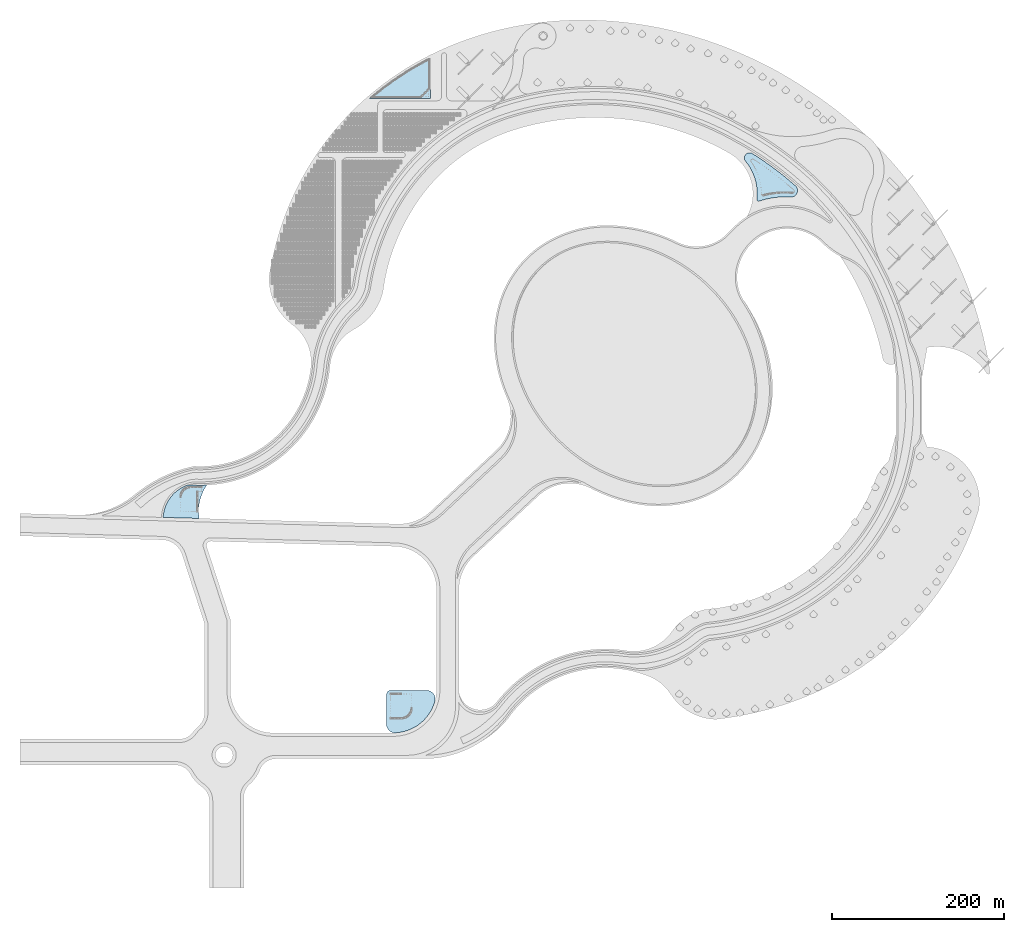
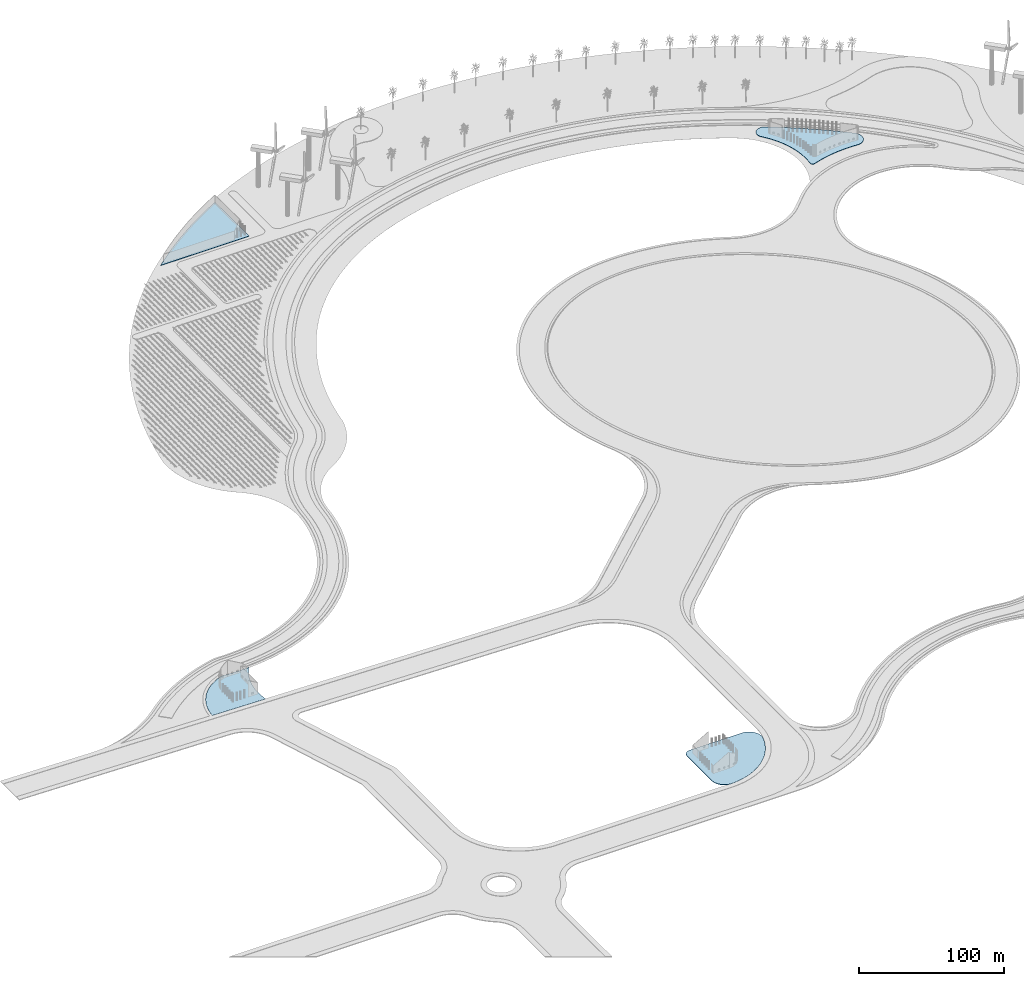
# One storey, part 6 of 39: 4 slabs.
"""IFC2X3 building model written with IfcOpenShell, lengths in millimetres."""

from ifc_helpers import new_model, entity, si_unit, converted_unit, derived_unit, direction, frame, frame_2d, origin, place, context, subcontext, project, spatial, polyline, circle_curve, parameter, trimmed, segment, composite_curve, outline, extrude, material, layer, layer_set, layer_usage, element, save


model = new_model("IFC2X3")

# Units and contexts
model_context = context("Model", 3, precision=1e-06, world=origin(), true_north=direction((2.0, 6.12303176911189e-17, 1.0)))
context_of_model = context(None, 3, precision=1e-06, world=origin(), true_north=direction((2.0, 6.12303176911189e-17, 1.0)))
body_context = subcontext(model_context, "Body", "Model", "MODEL_VIEW")
ifc_project = project(units=[si_unit("LENGTHUNIT", "METRE", prefix="MILLI"), si_unit("AREAUNIT", "SQUARE_METRE", prefix="MILLI"), si_unit("VOLUMEUNIT", "CUBIC_METRE", prefix="MILLI"), converted_unit("PLANEANGLEUNIT", "DEGREE", entity("IfcRatioMeasure", 0.0174532925199433), si_unit("PLANEANGLEUNIT", "RADIAN"), dimensions=[0, 0, 0, 0, 0, 0, 0]), si_unit("MASSUNIT", "GRAM", prefix="KILO"), si_unit("TIMEUNIT", "SECOND"), si_unit("THERMODYNAMICTEMPERATUREUNIT", "KELVIN"), derived_unit("THERMALTRANSMITTANCEUNIT", [(si_unit("MASSUNIT", "GRAM", prefix="KILO"), 1), (si_unit("THERMODYNAMICTEMPERATUREUNIT", "KELVIN"), -1), (si_unit("TIMEUNIT", "SECOND"), -3)]), derived_unit("VOLUMETRICFLOWRATEUNIT", [(si_unit("LENGTHUNIT", "METRE"), 3), (si_unit("TIMEUNIT", "SECOND"), -1)])], contexts=[model_context, context_of_model])

# Site, building, storey
site_placement = place(None, origin())
site = spatial("IfcSite", under=ifc_project, at=site_placement, CompositionType="ELEMENT")
building_placement = place(site_placement, origin())
building = spatial("IfcBuilding", under=site, at=building_placement, CompositionType="ELEMENT")
storey_placement = place(building_placement, frame((0.0, 0.0, 4000.0)))
storey = spatial("IfcBuildingStorey", under=building, at=storey_placement, Name="Level 2", CompositionType="ELEMENT", Elevation=4000.0)

# Slabs
ifc_material_1 = material(Name="Concrete - Cast In Situ")
ifc_layer_1 = layer(ifc_material_1, 200.0)
ifc_material_2 = material(Name="Site - Sand")
ifc_layer_2 = layer(ifc_material_2, 12.0)
ifc_material_3 = material(Name="Site - Hardcore")
ifc_layer_3 = layer(ifc_material_3, 150.0)
ifc_layer_set = layer_set([ifc_layer_1, ifc_layer_2, ifc_layer_3], Name="Floor:Concrete-Commercial 362mm")
ifc_layer_usage_1 = layer_usage(ifc_layer_set, "AXIS3", "POSITIVE", 0.0)
slab_1_placement = place(storey_placement, origin())
element("IfcSlab", 1, at=slab_1_placement, inside=storey, material=ifc_layer_usage_1, Name="Floor:Concrete-Commercial 362mm", ObjectType="Floor:Concrete-Commercial 362mm", PredefinedType="FLOOR", context=body_context, shape_type="SweptSolid", body=[
    extrude(outline(composite_curve([segment(trimmed(circle_curve(frame_2d((19801.6780636941, 13581.5965505277), x_axis=(0.0336308908008505, -0.99943432159489)), 42278.9263949134), [parameter(290.912034389434)], [parameter(0.0)], True, "PARAMETER"), True, "CONTINUOUS"), segment(polyline([(21223.5560202564, -28673.4135687843), (18603.3279602423, 13086.4411747319)]), True, "CONTINUOUS"), segment(trimmed(circle_curve(frame_2d((5478.03645612684, 63707.2000462357), x_axis=(-0.499906650860794, -0.866079292201903)), 52294.6890782893), [parameter(0.0)], [parameter(44.5297546536854)], True, "PARAMETER"), False, "CONTINUOUS"), segment(trimmed(circle_curve(frame_2d((-170162.457562301, -2828.88034765561), x_axis=(1.0, 0.0)), 151000.000000002), [parameter(0.0)], [parameter(8.08798367097216)], True, "PARAMETER"), False, "CONTINUOUS")], self_intersect=False)), frame((-327151.744163545, 236483.117156819, 362.0), z_axis=(0.0, 0.0, 1.0), x_axis=(-0.0904376244211891, -0.995902121741415, 0.0)), (0.0, 0.0, -1.0), 362.0),
])
ifc_layer_usage_2 = layer_usage(ifc_layer_set, "AXIS3", "POSITIVE", 0.0)
slab_2_placement = place(storey_placement, origin())
element("IfcSlab", 2, at=slab_2_placement, inside=storey, material=ifc_layer_usage_2, Name="Floor:Concrete-Commercial 362mm", ObjectType="Floor:Concrete-Commercial 362mm", PredefinedType="FLOOR", context=body_context, shape_type="SweptSolid", body=[
    extrude(outline(composite_curve([segment(polyline([(-21513.7170633693, -19671.1497220005), (12675.6880060792, -19671.1497220005)]), True, "CONTINUOUS"), segment(trimmed(circle_curve(frame_2d((12675.6880060792, -14671.1497220005), x_axis=(0.0, -1.0)), 5000.0), [parameter(0.0)], [parameter(89.9999999999993)], True, "PARAMETER"), True, "CONTINUOUS"), segment(polyline([(17675.6880060792, -14671.1497220005), (17675.6880060792, 26765.1514230867)]), True, "CONTINUOUS"), segment(trimmed(circle_curve(frame_2d((7675.68800607917, 26765.1514230867), x_axis=(1.0, 0.0)), 10000.0), [parameter(0.0)], [parameter(105.59872167877)], True, "PARAMETER"), True, "CONTINUOUS"), segment(trimmed(circle_curve(frame_2d((18431.6212665113, -11761.5912331145), x_axis=(-0.268898331510798, 0.963168566406239)), 50000.0000000003), [parameter(0.0)], [parameter(71.4055767154527)], True, "PARAMETER"), True, "CONTINUOUS"), segment(trimmed(circle_curve(frame_2d((-21513.7170633693, -9671.14972200054), x_axis=(-0.998633458247014, 0.0522610377811361)), 9999.99999999997), [parameter(0.0)], [parameter(92.9957016057769)], True, "PARAMETER"), True, "CONTINUOUS")], self_intersect=False)), frame((-78926.2750412612, -280.358489627831, 362.0), z_axis=(0.0, 0.0, -1.0), x_axis=(0.0, 1.0, 0.0)), (0.0, 0.0, 1.0), 362.0),
])
ifc_layer_usage_3 = layer_usage(ifc_layer_set, "AXIS3", "POSITIVE", 0.0)
slab_3_placement = place(storey_placement, origin())
element("IfcSlab", 3, at=slab_3_placement, inside=storey, material=ifc_layer_usage_3, Name="Floor:Concrete-Commercial 362mm", ObjectType="Floor:Concrete-Commercial 362mm", PredefinedType="FLOOR", context=body_context, shape_type="SweptSolid", body=[
    extrude(outline(composite_curve([segment(trimmed(circle_curve(frame_2d((-343626.154771461, -32503.960596042), x_axis=(1.0, 0.0)), 363900.403312327), [parameter(0.0)], [parameter(10.0007730172658)], True, "PARAMETER"), True, "CONTINUOUS"), segment(trimmed(circle_curve(frame_2d((7436.90672237789, 28780.579640498), x_axis=(0.967471750220284, 0.252979075536132)), 7553.73418363679), [parameter(0.0)], [parameter(137.601517778318)], True, "PARAMETER"), True, "CONTINUOUS"), segment(trimmed(circle_curve(frame_2d((-81104.4562036789, 75353.8164107798), x_axis=(0.88503140793182, -0.465531317167915)), 92489.453150956), [parameter(337.079998573377)], [parameter(0.0)], True, "PARAMETER"), False, "CONTINUOUS"), segment(trimmed(circle_curve(frame_2d((-21211.4974731398, 2271.05338646169), x_axis=(-0.633858666056767, 0.773448893916793)), 2000.00000000004), [parameter(0.0)], [parameter(115.250526606493)], True, "PARAMETER"), True, "CONTINUOUS"), segment(trimmed(circle_curve(frame_2d((-47390.0889784387, -52825.9641988732), x_axis=(0.42915723787155, 0.903229796502274)), 59000.0000000001), [parameter(313.237304627097)], [parameter(0.0)], True, "PARAMETER"), False, "CONTINUOUS"), segment(trimmed(circle_curve(frame_2d((14164.8695213847, -31799.9880226732), x_axis=(-0.875903878244571, -0.482485643180553)), 6149.8040121398), [parameter(0.0)], [parameter(144.579031788767)], True, "PARAMETER"), True, "CONTINUOUS")], self_intersect=False)), frame((342074.880669984, 605754.592030155, 362.0), z_axis=(0.0, 0.0, -1.0), x_axis=(0.527305959342565, 0.849675482311816, 0.0)), (0.0, 0.0, 1.0), 362.0),
])
ifc_layer_usage_4 = layer_usage(ifc_layer_set, "AXIS3", "POSITIVE", 0.0)
slab_4_placement = place(storey_placement, origin())
element("IfcSlab", 4, at=slab_4_placement, inside=storey, material=ifc_layer_usage_4, Name="Floor:Concrete-Commercial 362mm", ObjectType="Floor:Concrete-Commercial 362mm", PredefinedType="FLOOR", context=body_context, shape_type="SweptSolid", body=[
    extrude(outline(composite_curve([segment(polyline([(-23511.0335318463, 15702.0003881885), (-23511.0335318463, -31404.0007763785)]), True, "CONTINUOUS"), segment(trimmed(circle_curve(frame_2d((-179549.300054929, 278594.920827653), x_axis=(0.652839676753501, -0.757496109814383)), 347055.142614529), [parameter(345.962398561533)], [parameter(0.0)], True, "PARAMETER"), True, "CONTINUOUS"), segment(polyline([(47022.0670636925, 15702.0003881885), (-23511.0335318463, 15702.0003881885)]), True, "CONTINUOUS")], self_intersect=False)), frame((-71140.5474795315, 719657.779705868, 362.0), z_axis=(0.0, 0.0, 1.0), x_axis=(-1.0, 0.0, 0.0)), (0.0, 0.0, -1.0), 362.0),
])

save(model, "model.ifc")
